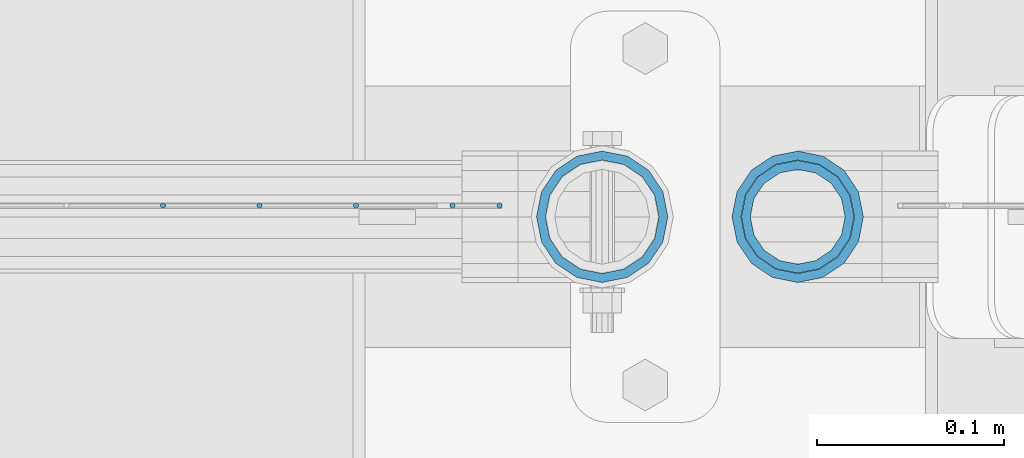
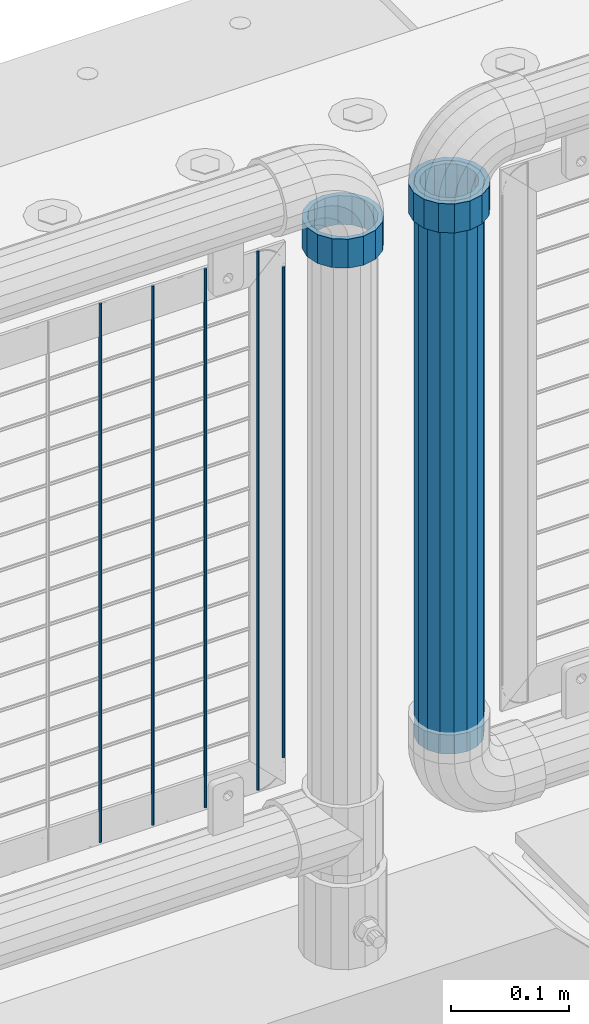
# One storey, part 91 of 219: 8 columns.
"""IFC2X3 building model written with IfcOpenShell, lengths in millimetres."""

from ifc_helpers import new_model, si_unit, frame, origin_with_axes, place, context, subcontext, project, spatial, faceted_brep, material, type_object, element, save


model = new_model("IFC2X3")

# Units and contexts
model_context = context("Model", 3, precision=1e-05, world=origin_with_axes())
body_context = subcontext(model_context, "Body", "Model", "MODEL_VIEW")
ifc_project = project(units=[si_unit("LENGTHUNIT", "METRE", prefix="MILLI"), si_unit("AREAUNIT", "SQUARE_METRE"), si_unit("VOLUMEUNIT", "CUBIC_METRE"), si_unit("MASSUNIT", "GRAM", prefix="KILO"), si_unit("TIMEUNIT", "SECOND"), si_unit("PLANEANGLEUNIT", "RADIAN"), si_unit("SOLIDANGLEUNIT", "STERADIAN"), si_unit("THERMODYNAMICTEMPERATUREUNIT", "DEGREE_CELSIUS"), si_unit("LUMINOUSINTENSITYUNIT", "LUMEN")], contexts=[model_context])

# Site, building, storey
site_placement = place(None, origin_with_axes())
site = spatial("IfcSite", under=ifc_project, at=site_placement, CompositionType="ELEMENT")
building_placement = place(site_placement, origin_with_axes())
building = spatial("IfcBuilding", under=site, at=building_placement, Name="Standard", CompositionType="ELEMENT")
storey_placement = place(building_placement, origin_with_axes())
storey = spatial("IfcBuildingStorey", under=building, at=storey_placement, Name="Undefined", CompositionType="ELEMENT", Elevation=0.0)

# Columns
ifc_material_1 = material(Name="Misc_Undefined")
column_type_1 = type_object("IfcColumnType", PredefinedType="NOTDEFINED")
column_1_placement = place(storey_placement, frame((12227.0, 31664.5, 894.85), z_axis=(1.0, 0.0, 0.0), x_axis=(0.0, 0.0, 1.0)))
element("IfcColumn", 1, at=column_1_placement, inside=storey, type_object=column_type_1, material=ifc_material_1, context=body_context, shape_type="Brep", body=[
    faceted_brep([(0.0, -30.3499999999985, 0.0), (0.0, -28.0397438117179, 11.6144421722802), (30.0, -28.0397438117179, 11.6144421722805), (30.0, -30.3499999999985, 0.0), (0.0, -21.46069080901, 21.4606908090118), (30.0, -21.46069080901, 21.4606908090117), (0.0, -11.614442172282, 28.0397438117179), (30.0, -11.614442172282, 28.0397438117176), (0.0, 0.0, 30.3500000000004), (30.0, 0.0, 30.35), (0.0, 11.614442172282, 28.0397438117179), (30.0, 11.614442172282, 28.0397438117176), (0.0, 21.46069080901, 21.4606908090118), (30.0, 21.46069080901, 21.4606908090117), (0.0, 28.0397438117179, 11.6144421722802), (30.0, 28.0397438117179, 11.6144421722805), (0.0, 30.3499999999985, 0.0), (30.0, 30.3499999999985, 0.0), (0.0, 28.0397438117179, -11.6144421722802), (30.0, 28.0397438117179, -11.6144421722805), (0.0, 21.46069080901, -21.4606908090118), (30.0, 21.46069080901, -21.4606908090117), (0.0, 11.614442172282, -28.0397438117179), (30.0, 11.614442172282, -28.0397438117176), (0.0, 0.0, -30.3500000000004), (30.0, 0.0, -30.35), (0.0, -11.614442172282, -28.0397438117179), (30.0, -11.614442172282, -28.0397438117176), (0.0, -21.46069080901, -21.4606908090118), (30.0, -21.46069080901, -21.4606908090117), (0.0, -28.0397438117179, -11.6144421722802), (30.0, -28.0397438117179, -11.6144421722805), (0.0, -35.1500000000015, 0.0), (0.0, -32.4743655677703, -13.4513226476338), (30.0, -32.4743655677703, -13.4513226476329), (30.0, -35.1500000000015, 0.0), (0.0, -24.8548033587067, -24.8548033587067), (30.0, -24.8548033587067, -24.8548033587072), (0.0, -13.4513226476338, -32.4743655677721), (30.0, -13.4513226476338, -32.4743655677718), (0.0, 0.0, -35.1500000000015), (30.0, 0.0, -35.15), (0.0, 13.4513226476338, -32.4743655677721), (30.0, 13.4513226476338, -32.4743655677718), (0.0, 24.8548033587067, -24.8548033587067), (30.0, 24.8548033587067, -24.8548033587072), (0.0, 32.4743655677703, -13.4513226476338), (30.0, 32.4743655677703, -13.4513226476329), (0.0, 35.1500000000015, 0.0), (30.0, 35.1500000000015, 0.0), (0.0, 32.4743655677703, 13.4513226476338), (30.0, 32.4743655677703, 13.4513226476329), (0.0, 24.8548033587067, 24.8548033587067), (30.0, 24.8548033587067, 24.8548033587072), (0.0, 13.4513226476338, 32.4743655677721), (30.0, 13.4513226476338, 32.4743655677718), (0.0, 0.0, 35.1500000000015), (30.0, 0.0, 35.15), (0.0, -13.4513226476338, 32.4743655677721), (30.0, -13.4513226476338, 32.4743655677718), (0.0, -24.8548033587067, 24.8548033587067), (30.0, -24.8548033587067, 24.8548033587072), (0.0, -32.4743655677703, 13.4513226476338), (30.0, -32.4743655677703, 13.4513226476329)], [[[0, 1, 2, 3]], [[1, 4, 5, 2]], [[4, 6, 7, 5]], [[6, 8, 9, 7]], [[8, 10, 11, 9]], [[10, 12, 13, 11]], [[12, 14, 15, 13]], [[14, 16, 17, 15]], [[16, 18, 19, 17]], [[18, 20, 21, 19]], [[20, 22, 23, 21]], [[22, 24, 25, 23]], [[24, 26, 27, 25]], [[26, 28, 29, 27]], [[28, 30, 31, 29]], [[30, 0, 3, 31]], [[32, 33, 34, 35]], [[33, 36, 37, 34]], [[36, 38, 39, 37]], [[38, 40, 41, 39]], [[40, 42, 43, 41]], [[42, 44, 45, 43]], [[44, 46, 47, 45]], [[46, 48, 49, 47]], [[48, 50, 51, 49]], [[50, 52, 53, 51]], [[52, 54, 55, 53]], [[54, 56, 57, 55]], [[56, 58, 59, 57]], [[58, 60, 61, 59]], [[60, 62, 63, 61]], [[62, 32, 35, 63]], [[37, 39, 41, 43, 45, 47, 49, 51, 53, 55, 57, 59, 61, 63, 35, 34], [5, 7, 9, 11, 13, 15, 17, 19, 21, 23, 25, 27, 29, 31, 3, 2]], [[62, 60, 58, 56, 54, 52, 50, 48, 46, 44, 42, 40, 38, 36, 33, 32], [30, 28, 26, 24, 22, 20, 18, 16, 14, 12, 10, 8, 6, 4, 1, 0]]]),
])
column_2_placement = place(storey_placement, frame((12331.61, 31664.5, 894.849999999999), z_axis=(-1.0, 0.0, 0.0), x_axis=(0.0, 0.0, 1.0)))
element("IfcColumn", 2, at=column_2_placement, inside=storey, type_object=column_type_1, material=ifc_material_1, context=body_context, shape_type="Brep", body=[
    faceted_brep([(0.0, -30.3499999999985, 0.0), (0.0, -28.0397438117179, 11.6144421722802), (30.0, -28.0397438117179, 11.6144421722805), (30.0, -30.3499999999985, 0.0), (0.0, -21.46069080901, 21.4606908090118), (30.0, -21.46069080901, 21.4606908090117), (0.0, -11.614442172282, 28.0397438117179), (30.0, -11.614442172282, 28.0397438117176), (0.0, 0.0, 30.3500000000004), (30.0, 0.0, 30.35), (0.0, 11.614442172282, 28.0397438117179), (30.0, 11.614442172282, 28.0397438117176), (0.0, 21.46069080901, 21.4606908090118), (30.0, 21.46069080901, 21.4606908090117), (0.0, 28.0397438117179, 11.6144421722802), (30.0, 28.0397438117179, 11.6144421722805), (0.0, 30.3499999999985, 0.0), (30.0, 30.3499999999985, 0.0), (0.0, 28.0397438117179, -11.6144421722802), (30.0, 28.0397438117179, -11.6144421722805), (0.0, 21.46069080901, -21.4606908090118), (30.0, 21.46069080901, -21.4606908090117), (0.0, 11.614442172282, -28.0397438117179), (30.0, 11.614442172282, -28.0397438117176), (0.0, 0.0, -30.3500000000004), (30.0, 0.0, -30.35), (0.0, -11.614442172282, -28.0397438117179), (30.0, -11.614442172282, -28.0397438117176), (0.0, -21.46069080901, -21.4606908090118), (30.0, -21.46069080901, -21.4606908090117), (0.0, -28.0397438117179, -11.6144421722802), (30.0, -28.0397438117179, -11.6144421722805), (0.0, -35.1500000000015, 0.0), (0.0, -32.4743655677703, -13.4513226476338), (30.0, -32.4743655677703, -13.4513226476329), (30.0, -35.1500000000015, 0.0), (0.0, -24.8548033587067, -24.8548033587067), (30.0, -24.8548033587067, -24.8548033587072), (0.0, -13.4513226476338, -32.4743655677721), (30.0, -13.4513226476338, -32.4743655677718), (0.0, 0.0, -35.1500000000015), (30.0, 0.0, -35.15), (0.0, 13.4513226476338, -32.4743655677721), (30.0, 13.4513226476338, -32.4743655677718), (0.0, 24.8548033587067, -24.8548033587067), (30.0, 24.8548033587067, -24.8548033587072), (0.0, 32.4743655677703, -13.4513226476338), (30.0, 32.4743655677703, -13.4513226476329), (0.0, 35.1500000000015, 0.0), (30.0, 35.1500000000015, 0.0), (0.0, 32.4743655677703, 13.4513226476338), (30.0, 32.4743655677703, 13.4513226476329), (0.0, 24.8548033587067, 24.8548033587067), (30.0, 24.8548033587067, 24.8548033587072), (0.0, 13.4513226476338, 32.4743655677721), (30.0, 13.4513226476338, 32.4743655677718), (0.0, 0.0, 35.1500000000015), (30.0, 0.0, 35.15), (0.0, -13.4513226476338, 32.4743655677721), (30.0, -13.4513226476338, 32.4743655677718), (0.0, -24.8548033587067, 24.8548033587067), (30.0, -24.8548033587067, 24.8548033587072), (0.0, -32.4743655677703, 13.4513226476338), (30.0, -32.4743655677703, 13.4513226476329)], [[[0, 1, 2, 3]], [[1, 4, 5, 2]], [[4, 6, 7, 5]], [[6, 8, 9, 7]], [[8, 10, 11, 9]], [[10, 12, 13, 11]], [[12, 14, 15, 13]], [[14, 16, 17, 15]], [[16, 18, 19, 17]], [[18, 20, 21, 19]], [[20, 22, 23, 21]], [[22, 24, 25, 23]], [[24, 26, 27, 25]], [[26, 28, 29, 27]], [[28, 30, 31, 29]], [[30, 0, 3, 31]], [[32, 33, 34, 35]], [[33, 36, 37, 34]], [[36, 38, 39, 37]], [[38, 40, 41, 39]], [[40, 42, 43, 41]], [[42, 44, 45, 43]], [[44, 46, 47, 45]], [[46, 48, 49, 47]], [[48, 50, 51, 49]], [[50, 52, 53, 51]], [[52, 54, 55, 53]], [[54, 56, 57, 55]], [[56, 58, 59, 57]], [[58, 60, 61, 59]], [[60, 62, 63, 61]], [[62, 32, 35, 63]], [[37, 39, 41, 43, 45, 47, 49, 51, 53, 55, 57, 59, 61, 63, 35, 34], [5, 7, 9, 11, 13, 15, 17, 19, 21, 23, 25, 27, 29, 31, 3, 2]], [[62, 60, 58, 56, 54, 52, 50, 48, 46, 44, 42, 40, 38, 36, 33, 32], [30, 28, 26, 24, 22, 20, 18, 16, 14, 12, 10, 8, 6, 4, 1, 0]]]),
])
ifc_material_2 = material()
column_type_2 = type_object("IfcColumnType", PredefinedType="NOTDEFINED")
column_3_placement = place(storey_placement, frame((12331.61, 31664.5, 349.86), z_axis=(-1.0, 0.0, 0.0), x_axis=(0.0, 0.0, 1.0)))
element("IfcColumn", 3, at=column_3_placement, inside=storey, type_object=column_type_2, material=ifc_material_2, context=body_context, shape_type="Brep", body=[
    faceted_brep([(0.0, -25.3499999999985, 0.0), (0.0, -23.4203461491597, 9.70102501045585), (574.992910334213, -23.4203461491597, 9.70102501045585), (574.990000024649, -25.3499999999985, 0.0), (0.0, -17.9251569030785, 17.9251569030785), (574.995377579387, -17.9251569030785, 17.9251569030785), (0.0, -9.70102501045403, 23.4203461491616), (574.997026144459, -9.70102501045403, 23.4203461491616), (0.0, 0.0, 25.3500000000004), (574.997605050341, 0.0, 25.3500000000004), (0.0, 9.70102501045403, 23.4203461491616), (574.997026163861, 9.70102501045403, 23.4203461491616), (0.0, 17.9251569030785, 17.9251569030785), (574.995377615237, 17.9251569030785, 17.9251569030785), (0.0, 23.4203461491597, 9.70102501045585), (574.992910381054, 23.4203461491597, 9.70102501045585), (0.0, 25.3499999999985, 0.0), (574.990000075349, 25.3499999999985, 0.0), (0.0, 23.4203461491597, -9.70102501045585), (574.987089765785, 23.4203461491597, -9.70102501045585), (0.0, 17.9251569030785, -17.9251569030785), (574.984622520612, 17.9251569030785, -17.9251569030785), (0.0, 9.70102501045403, -23.4203461491616), (574.982973955539, 9.70102501045403, -23.4203461491616), (0.0, 0.0, -25.3500000000004), (574.982395049657, 0.0, -25.3500000000004), (0.0, -9.70102501045403, -23.4203461491616), (574.982973936137, -9.70102501045403, -23.4203461491616), (0.0, -17.9251569030785, -17.9251569030785), (574.984622484761, -17.9251569030785, -17.9251569030785), (0.0, -23.4203461491597, -9.70102501045585), (574.987089718945, -23.4203461491597, -9.70102501045585), (0.0, -30.1500000000015, 0.0), (0.0, -27.8549679052157, -11.5379054858076), (574.986538650343, -27.8549679052157, -11.5379054858076), (574.990000019849, -30.1500000000015, 0.0), (0.0, -21.3192694527752, -21.3192694527752), (574.983604247556, -21.3192694527752, -21.3192694527752), (0.0, -11.5379054858058, -27.8549679052157), (574.981643547714, -11.5379054858058, -27.8549679052157), (0.0, 0.0, -30.1499999999996), (574.980955049592, 0.0, -30.1499999999996), (0.0, 11.5379054858058, -27.8549679052157), (574.98164357079, 11.5379054858058, -27.8549679052157), (0.0, 21.3192694527752, -21.3192694527752), (574.983604290195, 21.3192694527752, -21.3192694527752), (0.0, 27.8549679052157, -11.5379054858076), (574.986538706053, 27.8549679052157, -11.5379054858076), (0.0, 30.1500000000015, 0.0), (574.990000080149, 30.1500000000015, 0.0), (0.0, 27.8549679052157, 11.5379054858076), (574.993461449656, 27.8549679052157, 11.5379054858076), (0.0, 21.3192694527752, 21.3192694527752), (574.996395852442, 21.3192694527752, 21.3192694527752), (0.0, 11.5379054858058, 27.8549679052157), (574.998356552285, 11.5379054858058, 27.8549679052157), (0.0, 0.0, 30.1499999999996), (574.999045050406, 0.0, 30.1499999999996), (0.0, -11.5379054858058, 27.8549679052157), (574.998356529209, -11.5379054858058, 27.8549679052157), (0.0, -21.3192694527752, 21.3192694527752), (574.996395809804, -21.3192694527752, 21.3192694527752), (0.0, -27.8549679052157, 11.5379054858076), (574.993461393946, -27.8549679052157, 11.5379054858076)], [[[0, 1, 2, 3]], [[1, 4, 5, 2]], [[4, 6, 7, 5]], [[6, 8, 9, 7]], [[8, 10, 11, 9]], [[10, 12, 13, 11]], [[12, 14, 15, 13]], [[14, 16, 17, 15]], [[16, 18, 19, 17]], [[18, 20, 21, 19]], [[20, 22, 23, 21]], [[22, 24, 25, 23]], [[24, 26, 27, 25]], [[26, 28, 29, 27]], [[28, 30, 31, 29]], [[30, 0, 3, 31]], [[32, 33, 34, 35]], [[33, 36, 37, 34]], [[36, 38, 39, 37]], [[38, 40, 41, 39]], [[40, 42, 43, 41]], [[42, 44, 45, 43]], [[44, 46, 47, 45]], [[46, 48, 49, 47]], [[48, 50, 51, 49]], [[50, 52, 53, 51]], [[52, 54, 55, 53]], [[54, 56, 57, 55]], [[56, 58, 59, 57]], [[58, 60, 61, 59]], [[60, 62, 63, 61]], [[62, 32, 35, 63]], [[37, 39, 41, 43, 45, 47, 49, 51, 53, 55, 57, 59, 61, 63, 35, 34], [5, 7, 9, 11, 13, 15, 17, 19, 21, 23, 25, 27, 29, 31, 3, 2]], [[62, 60, 58, 56, 54, 52, 50, 48, 46, 44, 42, 40, 38, 36, 33, 32], [30, 28, 26, 24, 22, 20, 18, 16, 14, 12, 10, 8, 6, 4, 1, 0]]]),
])
column_type_3 = type_object("IfcColumnType", Name="D3", PredefinedType="NOTDEFINED")
for number, where, z_axis, x_axis in (
    (4, (12095.34, 31670.5, 353.020000000001), (-1.0, 0.0, 0.0), (0.0, 0.0, 1.0)),
    (5, (12043.685, 31670.5, 353.020000000001), (-1.0, 0.0, 0.0), (0.0, 0.0, 1.0)),
    (6, (11992.03, 31670.5, 353.020000000001), (-1.0, 0.0, 0.0), (0.0, 0.0, 1.0)),
    (7, (12146.995, 31670.5, 353.020000000001), (-1.0, 0.0, 0.0), (0.0, 0.0, 1.0)),
):
    element("IfcColumn", number, at=place(storey_placement, frame(where, z_axis=z_axis, x_axis=x_axis)), inside=storey, type_object=column_type_3, material=ifc_material_1, ObjectType="D3", context=body_context, shape_type="Brep", body=[
        faceted_brep([(0.0, -1.5, -5.6843418860808e-14), (0.0, -0.75, -1.29903810567669), (560.0, -0.75, -1.29903810567703), (560.0, -1.5, 0.0), (0.0, 0.75, -1.29903810567669), (560.0, 0.75, -1.29903810567703), (0.0, 1.5, -5.6843418860808e-14), (560.0, 1.5, 0.0), (0.0, 0.75, 1.29903810567669), (560.0, 0.75, 1.29903810567703), (0.0, -0.75, 1.29903810567669), (560.0, -0.75, 1.29903810567703)], [[[0, 1, 2, 3]], [[1, 4, 5, 2]], [[4, 6, 7, 5]], [[6, 8, 9, 7]], [[8, 10, 11, 9]], [[10, 0, 3, 11]], [[5, 7, 9, 11, 3, 2]], [[10, 8, 6, 4, 1, 0]]]),
    ])
column_4_placement = place(storey_placement, frame((12172.0, 31670.5, 378.020000000001), z_axis=(-1.0, 0.0, 0.0), x_axis=(0.0, 0.0, 1.0)))
element("IfcColumn", 8, at=column_4_placement, inside=storey, type_object=column_type_3, material=ifc_material_1, ObjectType="D3", context=body_context, shape_type="Brep", body=[
    faceted_brep([(0.0, -1.5, -5.6843418860808e-14), (0.0, -0.75, -1.29903810567669), (510.0, -0.75, -1.29903810567703), (510.0, -1.5, 0.0), (0.0, 0.75, -1.29903810567669), (510.0, 0.75, -1.29903810567703), (0.0, 1.5, -5.6843418860808e-14), (510.0, 1.5, 0.0), (0.0, 0.75, 1.29903810567669), (510.0, 0.75, 1.29903810567703), (0.0, -0.75, 1.29903810567669), (510.0, -0.75, 1.29903810567703)], [[[0, 1, 2, 3]], [[1, 4, 5, 2]], [[4, 6, 7, 5]], [[6, 8, 9, 7]], [[8, 10, 11, 9]], [[10, 0, 3, 11]], [[5, 7, 9, 11, 3, 2]], [[10, 8, 6, 4, 1, 0]]]),
])

save(model, "model.ifc")
